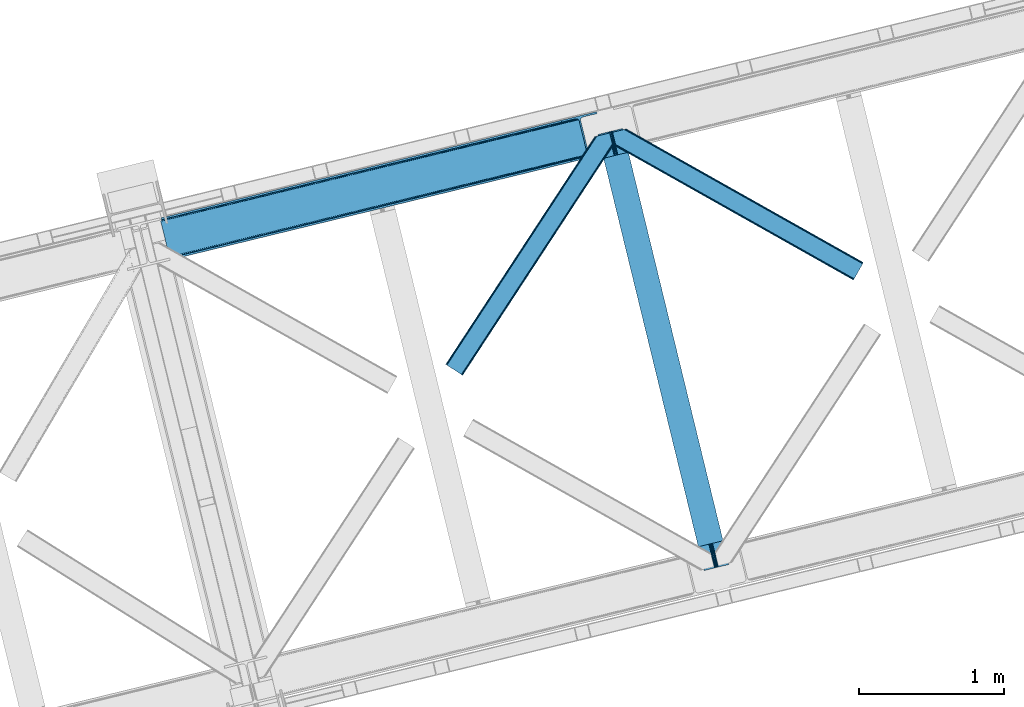
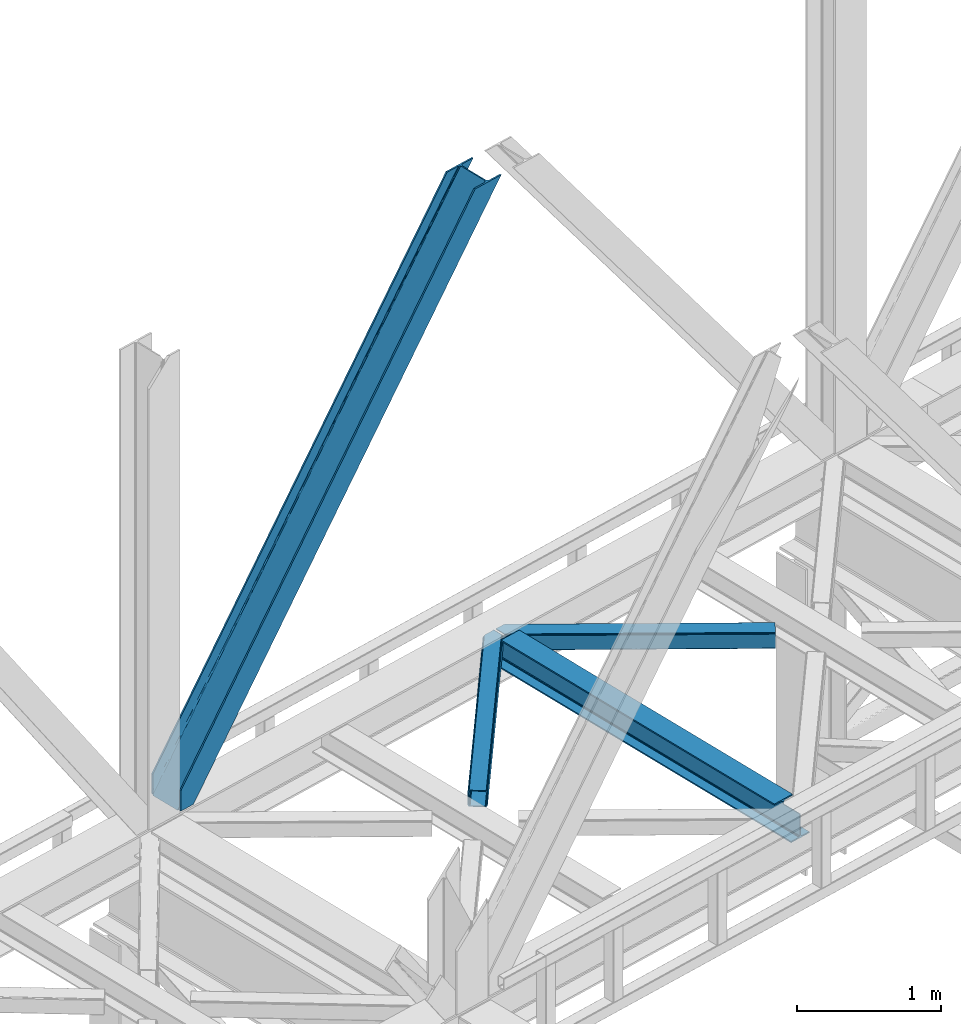
# One storey, part 41 of 92: 3 members, 1 beam.
"""IFC4 building model written with IfcOpenShell, lengths in millimetres."""

from ifc_helpers import new_model, entity, si_unit, converted_unit, derived_unit, direction, frame, origin, place, context, subcontext, project, spatial, triangles, polygons, material, type_object, element, save


model = new_model("IFC4")

# Units and contexts
model_context = context("Model", 3, precision=0.01, world=origin(), true_north=direction((6.12303176911189e-17, 1.0)))
plan_context = context("Plan", 3, precision=0.01, world=origin(), true_north=direction((6.12303176911189e-17, 1.0)))
body_context = subcontext(model_context, "Body", "Model", "MODEL_VIEW")
ifc_project = project(units=[si_unit("LENGTHUNIT", "METRE", prefix="MILLI"), si_unit("AREAUNIT", "SQUARE_METRE"), si_unit("VOLUMEUNIT", "CUBIC_METRE"), converted_unit("PLANEANGLEUNIT", "DEGREE", entity("IfcRatioMeasure", 0.0174532925199433), si_unit("PLANEANGLEUNIT", "RADIAN"), dimensions=[0, 0, 0, 0, 0, 0, 0]), si_unit("MASSUNIT", "GRAM", prefix="KILO"), derived_unit("MASSDENSITYUNIT", [(si_unit("MASSUNIT", "GRAM", prefix="KILO"), 1), (si_unit("LENGTHUNIT", "METRE"), -3)]), derived_unit("MOMENTOFINERTIAUNIT", [(si_unit("LENGTHUNIT", "METRE"), 4)]), si_unit("TIMEUNIT", "SECOND"), si_unit("FREQUENCYUNIT", "HERTZ"), si_unit("THERMODYNAMICTEMPERATUREUNIT", "DEGREE_CELSIUS"), derived_unit("THERMALTRANSMITTANCEUNIT", [(si_unit("MASSUNIT", "GRAM", prefix="KILO"), 1), (si_unit("THERMODYNAMICTEMPERATUREUNIT", "KELVIN"), -1), (si_unit("TIMEUNIT", "SECOND"), -3)]), derived_unit("VOLUMETRICFLOWRATEUNIT", [(si_unit("LENGTHUNIT", "METRE"), 3), (si_unit("TIMEUNIT", "SECOND"), -1)]), derived_unit("MASSFLOWRATEUNIT", [(si_unit("MASSUNIT", "GRAM", prefix="KILO"), 1), (si_unit("TIMEUNIT", "SECOND"), -1)]), derived_unit("ROTATIONALFREQUENCYUNIT", [(si_unit("TIMEUNIT", "SECOND"), -1)]), si_unit("ELECTRICCURRENTUNIT", "AMPERE"), si_unit("ELECTRICVOLTAGEUNIT", "VOLT"), si_unit("POWERUNIT", "WATT"), si_unit("FORCEUNIT", "NEWTON", prefix="KILO"), si_unit("ILLUMINANCEUNIT", "LUX"), si_unit("LUMINOUSFLUXUNIT", "LUMEN"), si_unit("LUMINOUSINTENSITYUNIT", "CANDELA"), derived_unit("USERDEFINED", [(si_unit("MASSUNIT", "GRAM", prefix="KILO"), -1), (si_unit("LENGTHUNIT", "METRE"), -2), (si_unit("TIMEUNIT", "SECOND"), 3), (si_unit("LUMINOUSFLUXUNIT", "LUMEN"), 1)]), derived_unit("LINEARVELOCITYUNIT", [(si_unit("LENGTHUNIT", "METRE"), 1), (si_unit("TIMEUNIT", "SECOND"), -1)]), si_unit("PRESSUREUNIT", "PASCAL"), derived_unit("USERDEFINED", [(si_unit("LENGTHUNIT", "METRE"), -2), (si_unit("MASSUNIT", "GRAM", prefix="KILO"), 1), (si_unit("TIMEUNIT", "SECOND"), -2)]), derived_unit("LINEARFORCEUNIT", [(si_unit("MASSUNIT", "GRAM", prefix="KILO"), 1), (si_unit("LENGTHUNIT", "METRE"), 1), (si_unit("TIMEUNIT", "SECOND"), -2), (si_unit("LENGTHUNIT", "METRE"), -1)]), derived_unit("PLANARFORCEUNIT", [(si_unit("MASSUNIT", "GRAM", prefix="KILO"), 1), (si_unit("LENGTHUNIT", "METRE"), 1), (si_unit("TIMEUNIT", "SECOND"), -2), (si_unit("LENGTHUNIT", "METRE"), -2)])], contexts=[model_context, plan_context])

# Site, building, storey
site_placement = place(None, origin())
site = spatial("IfcSite", under=ifc_project, at=site_placement, CompositionType="ELEMENT")
building_placement = place(site_placement, origin())
building = spatial("IfcBuilding", under=site, at=building_placement, CompositionType="ELEMENT")
storey_placement = place(building_placement, frame((0.0, 0.0, 15900.0)))
storey = spatial("IfcBuildingStorey", under=building, at=storey_placement, Name="05", CompositionType="ELEMENT", Elevation=15900.0)

# Beam
ifc_material = material(Name="Metal painted (White)")
beam_type = type_object("IfcBeamType", PredefinedType="BEAM")
beam_placement = place(storey_placement, frame((-46228.47, 6518.03, 3441.0)))
element("IfcBeam", 1, at=beam_placement, inside=storey, type_object=beam_type, material=ifc_material, ObjectType="Steel Beam", PredefinedType="BEAM", context=body_context, shape_type="Tessellation", body=[
    polygons([(900.98534618944, 41.4445662733125, 11.000000000004), (900.98534618944, 41.4445662733125, 2.16573425859679e-12), (170.021610174761, 3040.13999372697, 2.16573425859679e-12), (170.021610174761, 3040.13999372697, 11.000000000004), (834.919806235814, 25.3403919499689, 11.000000000004), (103.956070221135, 3024.03581940363, 11.000000000004), (828.971056214522, 23.8903211957407, 12.2179274798217), (98.0073201998427, 3022.5857486494, 12.2179274798217), (823.927949458422, 22.6610105689216, 15.6862915010192), (92.9642134437427, 3021.35643802258, 15.6862915010192), (820.558253255237, 21.839611468714, 20.8770650821657), (89.5945172405581, 3020.53503892237, 20.8770650821657), (819.374973305552, 21.5511744621238, 27.0000000000047), (88.4112372908723, 3020.24660191578, 27.0000000000047), (81.6103728838801, 3018.58881926485, 27.0000000000047), (81.6103728838801, 3018.58881926485, 203.000000000006), (88.4112372908723, 3020.24660191578, 203.000000000006), (0.0, 2998.69542745366, 2.16573425859679e-12), (0.0, 2998.69542745366, 10.9999999999997), (66.0655399536172, 3014.799601777, 11.000000000004), (72.0142899749184, 3016.24967253123, 12.2179274798217), (77.057396731027, 3017.47898315805, 15.6862915010192), (80.4270929341942, 3018.30038225826, 20.8770650821657), (819.374973305552, 21.5511744621238, 203.000000000006), (812.574108898559, 19.8933918111908, 203.000000000006), (812.574108898559, 19.8933918111908, 27.0000000000047), (811.390828948873, 19.6049548045995, 20.8770650821657), (808.021132745706, 18.783555704392, 15.6862915010192), (802.978025989589, 17.5542450775718, 12.2179274798217), (797.029275968296, 16.1041743233436, 11.000000000004), (730.963736014679, 3.24860138789518e-12, 10.9999999999997), (730.963736014679, 1.08286712929839e-12, 2.16573425859679e-12), (779.675212882749, 184.415062601697, 203.069791966819), (128.020401343512, 2857.75452019162, 203.000000000006), (128.243282132658, 2856.8401777572, 203.617301946336), (128.256196377177, 2856.7871977843, 217.000003693143), (779.530009633833, 185.010597404076, 217.000003676718), (779.530880241722, 185.007025963197, 204.00000679514), (772.96491171832, 182.385463974444, 203.006342981529), (772.742064056782, 183.299815969778, 203.617301946336), (772.729149812254, 183.352795942671, 217.000003693143), (121.455336555608, 2855.1293963229, 217.000003676718), (121.45446594771, 2855.13296776378, 204.00000679514), (121.310166358664, 2855.72494066435, 203.076120467494), (121.219536936511, 2856.09673754069, 203.000000000006), (780.71349435786, 185.298194377517, 223.122939328039), (784.082490766539, 186.122464201397, 228.313710402595), (789.125126170554, 187.3537084267, 231.782072735464), (795.073705041258, 188.804481281383, 232.999999602236), (861.139155906781, 204.909021065317, 232.999999283132), (861.137682570352, 204.91506504219, 243.999994005812), (691.116301666431, 163.4695582453, 243.999994827032), (691.117775002869, 163.463514268428, 233.000000104353), (757.183225868392, 179.568054052362, 232.999999785253), (763.132130996731, 181.017488520587, 231.782072861012), (768.175695503853, 182.244921343722, 228.313710479427), (771.546082413602, 183.063487001151, 223.12293937232), (120.271851831563, 2854.84179934946, 223.122939328039), (116.902855422893, 2854.01752952558, 228.313710402595), (111.860220018877, 2852.78628530027, 231.782072735464), (105.911641148165, 2851.33551244559, 232.999999602236), (39.8461902826419, 2835.23097266166, 232.999999283128), (39.8476636190794, 2835.22492868478, 243.999994005812), (209.869044522992, 2876.67043548167, 243.999994827032), (209.867571186554, 2876.67647945855, 233.000000104357), (143.802120321031, 2860.57193967461, 232.999999785253), (137.85321519271, 2859.12250520639, 231.782072861012), (132.809650685579, 2857.89507238325, 228.313710479427), (129.439263775838, 2857.07650672582, 223.12293937232)], [[[1, 2, 3, 4]], [[5, 1, 4, 6]], [[7, 5, 6, 8]], [[9, 7, 8, 10]], [[11, 9, 10, 12]], [[13, 11, 12, 14]], [[15, 16, 17, 14, 12, 10, 8, 6, 4, 3, 18, 19, 20, 21, 22, 23]], [[13, 24, 25, 26, 27, 28, 29, 30, 31, 32, 2, 1, 5, 7, 9, 11]], [[2, 32, 18, 3]], [[32, 31, 19, 18]], [[31, 30, 20, 19]], [[27, 26, 15, 23]], [[28, 27, 23, 22]], [[29, 28, 22, 21]], [[30, 29, 21, 20]], [[33, 24, 13, 14, 17, 34, 35, 36, 37, 38]], [[25, 39, 40, 41, 42, 43, 44, 16, 15, 26]], [[39, 25, 24, 33]], [[45, 34, 17, 16]], [[41, 40, 38, 37, 46, 47, 48, 49, 50, 51, 52, 53, 54, 55, 56, 57]], [[42, 58, 59, 60, 61, 62, 63, 64, 65, 66, 67, 68, 69, 36, 35, 43]], [[46, 37, 36, 69]], [[47, 46, 69, 68]], [[48, 47, 68, 67]], [[49, 48, 67, 66]], [[50, 49, 66, 65]], [[51, 50, 65, 64]], [[52, 51, 64, 63]], [[53, 52, 63, 62]], [[54, 53, 62, 61]], [[55, 54, 61, 60]], [[56, 55, 60, 59]], [[57, 56, 59, 58]], [[41, 57, 58, 42]]], closed=False),
])

# Members
member_type_1 = type_object("IfcMemberType", PredefinedType="BRACE")
member_1_placement = place(storey_placement, frame((-49235.85, 8657.06, 3695.0)))
element("IfcMember", 2, at=member_1_placement, inside=storey, type_object=member_type_1, ObjectType="Steel Vertical Brace", PredefinedType="BRACE", context=body_context, shape_type="Tessellation", body=[
    triangles([(58.5266601562544, 27.879693603516, 0.0), (60.4474731445371, 20.0011047363296, 0.0), (59.0987182617246, 20.928955078125, 0.827856445310317), (58.9684936523481, 19.7528640747078, 1.13248901367115), (72.2095458984404, 11.65800933838, 0.0), (71.3956420898467, 13.8997329711929, 30.563250732419), (70.228271484375, 15.4356857299808, 25.1542785644524), (72.2095458984404, 11.65800933838, 171.175598144531), (71.9258422851563, 12.6195785522468, 42.2602111816377), (71.9258422851563, 12.6195785522468, 171.115136718749), (70.3910522460938, 15.5595153808608, 0.0), (68.8144042968779, 17.2873168945316, 18.6337463378877), (67.2145019531308, 18.4651519775398, 14.6921264648408), (63.1682373046933, 19.9295974731449, 7.29955444335792), (63.1682373046933, 19.9295974731449, 0.0), (67.2145019531308, 18.4651519775398, 0.0), (2821.27895507813, 682.803089904786, 3911.00081176758), (2916.00805664063, 705.89354095459, 3911.00081176758), (2933.63488769531, 721.627464294434, 3911.00081176758), (2930.26300048828, 714.795323181153, 3911.00081176758), (2933.67209472656, 728.727030944825, 3911.00081176758), (2924.07268066407, 709.270079040529, 3911.00081176758), (2824.35783691407, 670.173046875001, 3911.00081176758), (75.0512329101621, 0.0, 171.175598144531), (75.0512329101621, 0.0, 0.0), (192.881250000006, 28.7220840454102, 0.0), (3068.02668457032, 729.569421386719, 3911.00081176758), (3064.94780273438, 742.199464416504, 3911.00081176758), (189.802368164063, 41.352708435059, 0.0), (2970.22335205079, 719.109594726564, 3911.00081176758), (95.0779174804702, 18.262257385255, 0.0), (2961.50295410157, 718.394522094728, 3911.00081176758), (86.3575195312515, 17.5471847534191, 0.0), (2953.46623535157, 720.451373291016, 3911.00081176758), (78.32080078125, 19.6040359497074, 0.0), (2947.33172607422, 724.965632629395, 3911.00081176758), (72.1862915039092, 24.1188766479499, 0.0), (2944.02960205078, 731.251295471193, 3911.00081176758), (68.8841674804717, 30.4039581298839, 0.0), (2888.84692382813, 957.622943115235, 3911.00081176758), (13.7014892578154, 256.775605773926, 0.0), (2888.88878173829, 964.722509765626, 3911.00081176758), (13.7433471679688, 263.875172424318, 0.0), (2892.25601806641, 971.554650878907, 3911.00081176758), (17.1105834960981, 270.707313537598, 0.0), (2898.44633789063, 977.079313659669, 3911.00081176758), (23.3009033203125, 276.232557678224, 0.0), (2906.51561279297, 980.457014465333, 3911.00081176758), (31.3701782226563, 279.609677124025, 0.0), (3001.24006347657, 1003.54688415527, 3911.00081176758), (126.094628906256, 302.700128173828, 0.0), (2998.16118164063, 1016.17750854492, 3911.00081176758), (123.015747070313, 315.330171203614, 0.0), (2878.49406738282, 955.098678588867, 3911.00081176758), (3.3486328125, 254.25134124756, 0.0), (2869.05743408203, 965.898600769044, 3911.00081176758), (2861.01606445313, 967.955451965332, 3911.00081176758), (2754.49698486328, 956.780552673341, 3911.00081176758), (2852.30031738282, 967.24096069336, 3911.00081176758), (2757.57586669922, 944.150509643556, 3911.00081176758), (2875.19194335938, 961.384341430665, 3911.00081176758), (5.18572998046875, 286.60750579834, 171.175598144531), (5.18572998046875, 286.60750579834, 0.0), (8.02741699219041, 274.948915100098, 171.175598144531), (8.22275390625146, 273.966416931153, 171.115136718749), (8.22275390625146, 273.966416931153, 42.2602111816377), (8.02741699219041, 274.948915100098, 0.0), (3.80906982422312, 263.445547485353, 0.0), (6.72982177734957, 266.608145141603, 0.0), (8.20880126953125, 270.64917755127, 0.0), (1.42781982422457, 262.13051147461, 0.0), (3.80906982422312, 263.445547485353, 7.29955444335792), (8.33902587890771, 272.585105895996, 30.563250732419), (8.20880126953125, 270.64917755127, 24.1799194335908), (7.30653076172166, 268.181886291504, 18.3872497558586), (6.72982177734957, 266.608145141603, 14.6921264648408), (0.0, 261.670074462891, 1.13248901367115), (0.65577392578416, 260.685250854493, 0.827856445310317)], [[1, 2, 3], [4, 3, 2], [5, 6, 7], [5, 8, 9], [10, 9, 8], [9, 6, 5], [11, 12, 13], [11, 7, 12], [14, 4, 2], [2, 15, 14], [16, 13, 14], [14, 15, 16], [13, 16, 11], [7, 11, 5], [17, 18, 10], [9, 10, 18], [19, 3, 14], [14, 20, 19], [14, 13, 20], [13, 12, 20], [3, 4, 14], [19, 21, 1], [1, 3, 19], [6, 20, 7], [6, 22, 20], [12, 7, 20], [18, 22, 9], [6, 9, 22], [8, 17, 10], [23, 8, 24], [8, 23, 17], [25, 24, 5], [8, 5, 24], [23, 26, 27], [26, 23, 24], [25, 26, 24], [28, 27, 29], [26, 29, 27], [30, 28, 29], [29, 31, 30], [32, 30, 31], [31, 33, 32], [34, 32, 33], [33, 35, 34], [36, 34, 35], [35, 37, 36], [38, 36, 37], [37, 39, 38], [40, 38, 39], [39, 41, 40], [42, 40, 43], [41, 43, 40], [44, 42, 45], [43, 45, 42], [46, 44, 47], [45, 47, 44], [48, 46, 49], [47, 49, 46], [50, 48, 51], [49, 51, 48], [52, 50, 53], [51, 53, 50], [21, 54, 55], [55, 1, 21], [54, 21, 40], [20, 22, 32], [18, 23, 27], [17, 23, 18], [22, 18, 30], [21, 19, 36], [19, 20, 34], [56, 46, 57], [58, 59, 52], [59, 57, 48], [58, 60, 59], [56, 61, 44], [61, 54, 42], [40, 21, 38], [30, 32, 22], [36, 19, 34], [32, 34, 20], [36, 38, 21], [27, 30, 18], [27, 28, 30], [48, 57, 46], [44, 61, 42], [40, 42, 54], [44, 46, 56], [48, 52, 59], [52, 48, 50], [58, 53, 62], [58, 52, 53], [53, 63, 62], [64, 58, 62], [60, 64, 65], [64, 60, 58], [59, 60, 65], [65, 66, 59], [67, 64, 62], [62, 63, 67], [11, 35, 5], [68, 41, 55], [69, 70, 43], [69, 43, 68], [55, 71, 68], [67, 63, 47], [67, 45, 70], [55, 39, 1], [37, 16, 15], [2, 1, 15], [15, 1, 39], [11, 16, 37], [25, 5, 33], [39, 55, 41], [49, 47, 63], [43, 70, 45], [47, 45, 67], [43, 41, 68], [53, 49, 63], [53, 51, 49], [31, 25, 33], [35, 11, 37], [39, 37, 15], [35, 33, 5], [31, 26, 25], [26, 31, 29], [72, 68, 71], [67, 73, 66], [67, 70, 74], [74, 73, 67], [64, 67, 66], [66, 65, 64], [75, 70, 76], [75, 74, 70], [69, 76, 70], [76, 69, 72], [68, 72, 69], [71, 77, 72], [78, 61, 72], [61, 56, 75], [75, 76, 61], [76, 72, 61], [56, 57, 73], [73, 74, 56], [57, 59, 66], [66, 73, 57], [74, 75, 56], [72, 77, 78], [54, 61, 55], [78, 55, 61], [71, 55, 78], [78, 77, 71]]),
])
member_type_2 = type_object("IfcMemberType", PredefinedType="BRACE")
member_2_placement = place(storey_placement, frame((-47275.26, 7859.97, 3511.0)))
element("IfcMember", 3, at=member_2_placement, inside=storey, type_object=member_type_2, ObjectType="Steel Horizontal Brace", PredefinedType="BRACE", context=body_context, shape_type="Tessellation", body=[
    triangles([(994.771838378903, 1564.02662658691, 0.0), (1028.82092285156, 1424.34736175537, 0.0), (14.6409667968692, 67.104043579101, 0.0), (102.482116699219, 9.58604278564417, 0.0), (1.11156005859084, 75.9604797363281, 10.8028289794929), (0.0, 76.6900863647461, 17.5000946044929), (1025.02580566406, 1642.17883300781, 17.5000946044929), (4.28811035156104, 73.8821182250977, 5.12526855468968), (990.474426269531, 1585.87703704834, 9.50058288574292), (990.041894531249, 1584.44747314453, 8.74132690429906), (989.907019042963, 1583.99226837158, 8.50064392089917), (990.758129882808, 1580.48841247559, 5.12526855468968), (1027.30473632812, 1642.73519439697, 10.8702667236357), (1027.77912597656, 1642.8503036499, 9.50058288574292), (992.599877929686, 1572.93538513184, 1.33247680664135), (9.03665771483793, 70.7724243164057, 1.33247680664135), (1025.02580566406, 1642.17883300781, 122.500662231447), (0.0, 76.6900863647461, 122.500662231447), (1026.9187133789, 1642.64101409912, 129.197927856447), (1.11156005859084, 75.9604797363281, 129.197927856447), (1032.31373291015, 1643.95605010986, 134.874325561526), (4.28811035156104, 73.8821182250977, 134.874325561526), (1040.39230957031, 1645.92395324707, 138.667117309571), (9.03665771483793, 70.7724243164057, 138.667117309571), (1049.91730957031, 1648.24590454102, 139.999594116212), (14.6409667968692, 67.104043579101, 139.999594116212), (994.869506835938, 1567.85139312744, 9.50058288574292), (994.757885742183, 1567.00667724609, 9.29478149414354), (994.646264648436, 1566.15091552734, 9.08781738281323), (994.539294433591, 1565.306199646, 8.8831787109375), (994.743933105463, 1564.14464263916, 8.50064392089917), (1047.05236816406, 1647.54827270508, 9.50058288574292), (14.892114257811, 66.9377746582031, 8.3320495605476), (20.4964233398423, 63.2693939208984, 6.99957275390625), (997.041467285155, 1554.71498565674, 6.99957275390625), (10.1435668945269, 70.0474685668942, 12.1260040283232), (1042.27126464844, 1646.3826461792, 12.1260040283232), (1036.87624511719, 1645.06761016846, 17.8035644531265), (1034.98333740234, 1644.60601043701, 24.4996673583992), (6.96701660155668, 72.1258300781246, 17.8035644531265), (5.85545654296584, 72.8554367065426, 24.4996673583992), (1026.55129394531, 1433.65958404541, 6.99957275390625), (96.6266601562456, 13.4206924438477, 6.99957275390625), (1028.71395263672, 1424.77640533447, 8.41343994140698), (1032.83463134765, 1407.88615722656, 5.12526855468968), (1033.6857421875, 1404.38230133057, 8.50064392089917), (1030.99288330078, 1415.43918457031, 1.33247680664135), (1034.98333740234, 1644.60601043701, 115.501089477541), (5.85545654296584, 72.8554367065426, 115.501089477541), (1050.34519042968, 1648.35113067627, 131.667544555665), (1059.87019042968, 1650.67308197021, 133.000021362306), (20.4964233398423, 63.2693939208984, 133.000021362306), (14.892114257811, 66.9377746582031, 131.667544555665), (1042.27126464844, 1646.3826461792, 127.87475280762), (10.1435668945269, 70.0474685668942, 127.87475280762), (1036.87624511719, 1645.06761016846, 122.196029663086), (6.96701660155668, 72.1258300781246, 122.196029663086), (1128.10788574218, 1667.30578765869, 139.999594116212), (1128.10788574218, 1667.30578765869, 133.000021362306), (1144.32550048828, 1600.75810546875, 139.999594116212), (102.482116699219, 9.58604278564417, 139.999594116212), (1142.05587158203, 1610.06974639893, 133.000021362306), (96.6266601562456, 13.4206924438477, 133.000021362306), (1146.4974609375, 1591.84934692383, 138.667117309571), (108.08642578125, 5.91766204833948, 138.667117309571), (1148.33920898437, 1584.29631958008, 134.874325561526), (112.834973144527, 2.80738677978479, 134.874325561526), (1149.57169189453, 1579.2501159668, 129.197927856447), (116.011523437497, 0.729606628417969, 129.197927856447), (1150.00422363281, 1577.47813110352, 122.500662231447), (117.123083496088, 0.0, 122.500662231447), (1150.00422363281, 1577.47813110352, 17.5000946044929), (117.123083496088, 0.0, 17.5000946044929), (106.979516601561, 6.64203643798828, 127.87475280762), (110.151416015622, 4.56425628662055, 122.196029663086), (111.267626953122, 3.83464965820258, 115.501089477541), (102.230969238277, 9.75231170654297, 131.667544555665), (116.011523437497, 0.729606628417969, 10.8028289794929), (106.979516601561, 6.64203643798828, 12.1260040283232), (112.834973144527, 2.80738677978479, 5.12526855468968), (111.267626953122, 3.83464965820258, 24.4996673583992), (110.151416015622, 4.56425628662055, 17.8035644531265), (108.08642578125, 5.91766204833948, 1.33247680664135), (102.230969238277, 9.75231170654297, 8.3320495605476), (1147.30206298828, 1588.56233825684, 122.196029663086), (1147.73459472656, 1586.78977203369, 115.501089477541), (1146.06958007813, 1593.60854187012, 127.87475280762), (1144.22783203125, 1601.160987854, 131.667544555665), (1147.73459472656, 1586.78977203369, 24.4996673583992), (1147.21369628906, 1588.9239440918, 17.869839477542), (1149.994921875, 1577.51591949463, 16.5001556396492), (1147.10672607421, 1589.36519622803, 16.5001556396492), (1145.27427978515, 1573.10804901123, 10.8714294433594), (1034.61591796875, 1404.78809051514, 9.50058288574292), (1144.12551269531, 1572.03427734375, 9.50058288574292), (1142.79071044922, 1588.5978012085, 12.1260040283232), (1030.22548828125, 1422.8143157959, 9.50058288574292), (1029.19764404296, 1423.6724029541, 8.80643920898729), (1139.7304321289, 1590.05992126465, 9.50058288574292)], [[1, 2, 3], [4, 3, 2], [5, 6, 7], [8, 9, 10], [11, 12, 8], [5, 13, 9], [9, 8, 5], [13, 14, 9], [15, 1, 16], [3, 16, 1], [12, 15, 8], [16, 8, 15], [7, 13, 5], [17, 7, 18], [6, 18, 7], [19, 17, 20], [18, 20, 17], [21, 19, 22], [20, 22, 19], [23, 21, 24], [22, 24, 21], [25, 23, 26], [24, 26, 23], [27, 28, 9], [28, 29, 10], [29, 30, 10], [30, 31, 11], [14, 32, 27], [27, 9, 14], [33, 34, 35], [36, 33, 31], [31, 30, 36], [28, 36, 29], [28, 27, 36], [36, 30, 29], [32, 37, 27], [36, 27, 37], [35, 31, 33], [38, 39, 40], [41, 40, 39], [37, 38, 36], [40, 36, 38], [42, 35, 34], [34, 43, 42], [1, 35, 42], [31, 12, 11], [1, 31, 35], [31, 15, 12], [31, 1, 15], [2, 1, 42], [44, 2, 42], [45, 44, 46], [44, 47, 2], [44, 45, 47], [39, 48, 41], [49, 41, 48], [50, 51, 52], [52, 53, 50], [54, 50, 53], [53, 55, 54], [56, 54, 55], [55, 57, 56], [48, 56, 57], [57, 49, 48], [56, 17, 19], [50, 23, 25], [58, 51, 25], [51, 58, 59], [51, 50, 25], [54, 23, 50], [54, 56, 21], [21, 23, 54], [19, 21, 56], [39, 7, 17], [37, 14, 38], [56, 48, 17], [37, 32, 14], [39, 38, 7], [48, 39, 17], [13, 7, 38], [38, 14, 13], [60, 25, 61], [25, 60, 58], [26, 61, 25], [51, 62, 63], [51, 59, 62], [63, 52, 51], [64, 60, 61], [61, 65, 64], [66, 64, 65], [65, 67, 66], [68, 66, 67], [67, 69, 68], [70, 68, 69], [69, 71, 70], [72, 70, 71], [71, 73, 72], [69, 74, 75], [76, 73, 71], [69, 75, 71], [69, 67, 74], [75, 76, 71], [74, 67, 65], [63, 61, 26], [61, 77, 65], [77, 61, 63], [77, 74, 65], [78, 79, 80], [81, 73, 76], [73, 82, 78], [82, 73, 81], [78, 82, 79], [4, 43, 3], [83, 80, 79], [79, 84, 83], [84, 43, 4], [4, 83, 84], [55, 24, 22], [26, 52, 63], [26, 53, 52], [53, 26, 24], [55, 53, 24], [49, 18, 6], [20, 57, 55], [22, 20, 55], [57, 20, 18], [49, 57, 18], [16, 36, 8], [3, 43, 34], [34, 33, 3], [33, 36, 16], [16, 3, 33], [5, 8, 36], [6, 41, 49], [40, 6, 5], [6, 40, 41], [40, 5, 36], [85, 86, 75], [76, 75, 86], [87, 85, 74], [75, 74, 85], [88, 87, 77], [74, 77, 87], [62, 88, 63], [77, 63, 88], [86, 89, 81], [81, 76, 86], [90, 91, 92], [70, 72, 89], [72, 90, 89], [89, 86, 70], [72, 91, 90], [85, 70, 86], [68, 70, 85], [66, 85, 87], [85, 66, 68], [87, 64, 66], [88, 64, 87], [88, 62, 60], [88, 60, 64], [62, 58, 60], [62, 59, 58], [73, 78, 93], [93, 72, 73], [94, 93, 78], [94, 95, 93], [80, 45, 46], [46, 78, 80], [46, 94, 78], [47, 45, 83], [80, 83, 45], [2, 47, 4], [83, 4, 47], [93, 91, 72], [82, 81, 89], [82, 92, 96], [82, 90, 92], [84, 97, 98], [79, 96, 97], [97, 84, 79], [96, 99, 97], [43, 84, 44], [44, 42, 43], [96, 79, 82], [89, 90, 82], [96, 91, 93], [96, 92, 91], [96, 95, 99], [93, 95, 96], [99, 95, 97], [94, 97, 95]]),
])
member_type_3 = type_object("IfcMemberType", PredefinedType="BRACE")
member_3_placement = place(storey_placement, frame((-46126.76, 8515.07, 3511.0)))
element("IfcMember", 4, at=member_3_placement, inside=storey, type_object=member_type_3, ObjectType="Steel Horizontal Brace", PredefinedType="BRACE", context=body_context, shape_type="Tessellation", body=[
    triangles([(1656.08961181641, 0.0, 122.500662231447), (1656.74538574219, 1.16097564697338, 129.197927856447), (23.8915649414048, 919.172964477539, 122.500662231447), (23.4590332031221, 920.944949340821, 129.197927856447), (1658.60573730469, 4.46600646972729, 134.874325561526), (22.231201171875, 925.991734313966, 134.874325561526), (1661.39161376953, 9.41337890625073, 138.667117309571), (20.3894531249971, 933.544180297851, 138.667117309571), (1664.67978515625, 15.2484878540035, 139.999594116212), (18.2174926757798, 942.452938842775, 139.999594116212), (1656.08961181641, 0.0, 17.5000946044929), (23.8915649414048, 919.172964477539, 17.5000946044929), (1716.20222167969, 106.738252258301, 139.999594116212), (69.4469238281235, 1034.10722808838, 139.999594116212), (0.0, 1017.17919158936, 139.999594116212), (1719.4857421875, 112.573361206056, 138.667117309571), (78.971923828125, 1036.42917938232, 138.667117309571), (1722.27161865235, 117.520152282716, 134.874325561526), (87.0458496093779, 1038.39708251953, 134.874325561526), (1724.13662109375, 120.825764465333, 129.197927856447), (92.4455200195298, 1039.71269989014, 129.197927856447), (1724.78774414062, 121.986740112305, 122.500662231447), (94.3384277343721, 1040.17429962158, 122.500662231447), (1724.78774414062, 121.986740112305, 17.5000946044929), (94.3384277343721, 1040.17429962158, 17.5000946044929), (1656.74538574219, 1.16097564697338, 10.8028289794929), (1658.60573730469, 4.46600646972729, 5.12526855468968), (196.057800292969, 824.821165466308, 8.8831787109375), (196.076403808591, 825.066499328614, 8.50064392089917), (23.3706665039063, 921.307136535645, 10.8691040039084), (195.062512207034, 824.998480224609, 9.50058288574292), (195.732238769531, 824.878720092775, 9.08316650390771), (23.263696289061, 921.747807312013, 9.50058288574292), (195.225292968753, 828.57035522461, 5.12526855468968), (1664.67978515625, 15.2484878540035, 0.0), (1661.39161376953, 9.41337890625073, 1.33247680664135), (193.383544921875, 836.123382568359, 1.33247680664135), (191.211584472658, 845.031559753419, 0.0), (1716.20222167969, 106.738252258301, 0.0), (157.162499999999, 984.710824584961, 0.0), (191.351110839845, 843.223530578614, 9.20757751465135), (191.295300292972, 844.068827819825, 8.85411071777344), (191.104614257813, 845.46060333252, 8.41343994140698), (18.8686157226548, 939.774032592773, 9.50058288574292), (1724.13662109375, 120.825764465333, 10.8028289794929), (92.0548461914077, 1039.61851959229, 10.8702667236357), (150.921020507813, 1006.08742675781, 9.50058288574292), (1722.27161865235, 117.520152282716, 5.12526855468968), (153.148791503903, 1001.17261047363, 5.12526855468968), (152.297680664065, 1004.67646636963, 8.50064392089917), (151.609350585939, 1005.38223724365, 9.00061340332104), (91.5851074218735, 1039.50341033936, 9.50058288574292), (1719.4857421875, 112.573361206056, 1.33247680664135), (154.990539550781, 993.620164489746, 1.33247680664135), (156.250927734378, 986.7019821167, 9.11688537597729), (155.813745117186, 987.634483337402, 9.42384338378906), (156.692761230472, 985.761341857911, 8.80760192871094), (157.134594726565, 984.828840637207, 8.50064392089917), (155.316101074219, 988.061782836914, 9.50058288574292), (72.3118652343765, 1034.80544128418, 9.50058288574292), (159.43212890625, 975.399183654785, 6.99957275390625), (188.941955566406, 854.343782043457, 6.99957275390625), (1668.11213378907, 21.3475341796875, 6.99957275390625), (1712.76522216797, 100.639205932617, 6.99957275390625), (19.9615722656235, 935.303375244141, 12.1260040283232), (1662.04273681641, 10.5656341552731, 12.1260040283232), (1664.82861328125, 15.5124252319347, 8.3320495605476), (1659.52661132813, 6.09904632568396, 24.4996673583992), (1660.177734375, 7.26002197265734, 17.8035644531265), (21.6219360351533, 928.484605407715, 24.4996673583992), (21.1894042968779, 930.257171630859, 17.8035644531265), (1716.05339355468, 106.474314880372, 8.3320495605476), (1718.83927001953, 111.421105957032, 12.1260040283232), (77.0929687500029, 1035.9704864502, 12.1260040283232), (1720.69962158203, 114.726718139649, 17.8035644531265), (82.4879882812529, 1037.28552246094, 17.8035644531265), (1721.35074462891, 115.887112426759, 24.4996673583992), (84.3808959960952, 1037.74770355225, 24.4996673583992), (1659.52661132813, 6.09904632568396, 115.501089477541), (21.6219360351533, 928.484605407715, 115.501089477541), (21.1894042968779, 930.257171630859, 122.196029663086), (19.9615722656235, 935.303375244141, 127.87475280762), (15.9478637695283, 951.764579772949, 133.000021362306), (18.1198242187529, 942.855821228028, 131.667544555665), (0.0, 1017.17919158936, 133.000021362306), (1668.11213378907, 21.3475341796875, 133.000021362306), (1664.82861328125, 15.5124252319347, 131.667544555665), (1662.04273681641, 10.5656341552731, 127.87475280762), (1660.177734375, 7.26002197265734, 122.196029663086), (1718.83927001953, 111.421105957032, 127.87475280762), (1720.69962158203, 114.726718139649, 122.196029663086), (1721.35074462891, 115.887112426759, 115.501089477541), (1712.76522216797, 100.639205932617, 133.000021362306), (1716.05339355468, 106.474314880372, 131.667544555665), (77.0929687500029, 1035.9704864502, 127.87475280762), (69.01904296875, 1034.00258331299, 131.667544555665), (82.4879882812529, 1037.28552246094, 122.196029663086), (59.4940429687485, 1031.68063201904, 133.000021362306), (84.3808959960952, 1037.74770355225, 115.501089477541)], [[1, 2, 3], [4, 3, 2], [2, 5, 4], [6, 4, 5], [5, 7, 6], [8, 6, 7], [7, 9, 8], [10, 8, 9], [11, 1, 12], [3, 12, 1], [13, 10, 9], [10, 13, 14], [15, 10, 14], [13, 16, 17], [17, 14, 13], [16, 18, 19], [19, 17, 16], [18, 20, 21], [21, 19, 18], [20, 22, 23], [23, 21, 20], [22, 24, 25], [25, 23, 22], [26, 11, 12], [27, 28, 29], [26, 30, 31], [31, 27, 26], [31, 32, 27], [30, 33, 31], [29, 34, 27], [35, 36, 37], [37, 38, 35], [36, 27, 34], [34, 37, 36], [12, 30, 26], [39, 35, 38], [38, 40, 39], [41, 42, 29], [42, 43, 29], [41, 31, 33], [33, 44, 41], [45, 46, 25], [46, 45, 47], [45, 48, 49], [49, 50, 45], [45, 50, 51], [51, 47, 45], [47, 52, 46], [48, 53, 54], [54, 49, 48], [53, 39, 40], [40, 54, 53], [25, 24, 45], [51, 55, 56], [50, 57, 55], [50, 58, 57], [47, 59, 52], [60, 52, 59], [61, 40, 62], [54, 58, 49], [58, 54, 40], [49, 58, 50], [40, 61, 58], [62, 40, 38], [37, 43, 38], [43, 37, 34], [38, 43, 62], [34, 29, 43], [63, 64, 62], [61, 62, 64], [63, 62, 43], [41, 65, 66], [41, 44, 65], [43, 66, 67], [66, 43, 42], [42, 41, 66], [43, 67, 63], [68, 69, 70], [71, 70, 69], [69, 66, 71], [65, 71, 66], [72, 58, 61], [57, 72, 55], [57, 58, 72], [56, 55, 72], [73, 74, 59], [59, 72, 73], [74, 60, 59], [73, 75, 76], [76, 74, 73], [75, 77, 78], [78, 76, 75], [61, 64, 72], [79, 68, 80], [70, 80, 68], [81, 6, 82], [80, 70, 3], [4, 81, 3], [81, 4, 6], [81, 80, 3], [70, 12, 3], [71, 65, 33], [33, 30, 71], [30, 12, 71], [70, 71, 12], [83, 10, 15], [10, 84, 8], [84, 10, 83], [15, 85, 83], [84, 82, 8], [44, 33, 65], [8, 82, 6], [86, 87, 84], [84, 83, 86], [87, 88, 82], [82, 84, 87], [88, 89, 81], [81, 82, 88], [89, 79, 80], [80, 81, 89], [20, 90, 91], [92, 24, 22], [20, 91, 22], [20, 18, 90], [91, 92, 22], [90, 18, 16], [93, 13, 9], [13, 94, 16], [94, 13, 93], [94, 90, 16], [45, 73, 48], [77, 24, 92], [24, 75, 45], [75, 24, 77], [45, 75, 73], [39, 64, 35], [53, 48, 73], [73, 72, 53], [72, 64, 39], [39, 53, 72], [88, 7, 5], [9, 86, 93], [9, 87, 86], [87, 9, 7], [88, 87, 7], [79, 1, 11], [2, 89, 88], [5, 2, 88], [89, 2, 1], [79, 89, 1], [36, 66, 27], [35, 64, 63], [63, 67, 35], [67, 66, 36], [36, 35, 67], [26, 27, 66], [11, 68, 79], [69, 11, 26], [11, 69, 68], [69, 26, 66], [95, 96, 17], [19, 95, 17], [19, 21, 97], [95, 19, 97], [97, 21, 23], [96, 14, 17], [15, 98, 85], [15, 14, 98], [96, 98, 14], [97, 23, 99], [78, 25, 76], [23, 78, 99], [25, 46, 76], [23, 25, 78], [52, 76, 46], [74, 76, 52], [60, 74, 52], [93, 83, 98], [93, 86, 83], [83, 85, 98], [77, 92, 78], [99, 78, 92], [92, 91, 99], [97, 99, 91], [91, 90, 97], [95, 97, 90], [90, 94, 95], [96, 95, 94], [94, 93, 96], [98, 96, 93]]),
])

save(model, "model.ifc")
